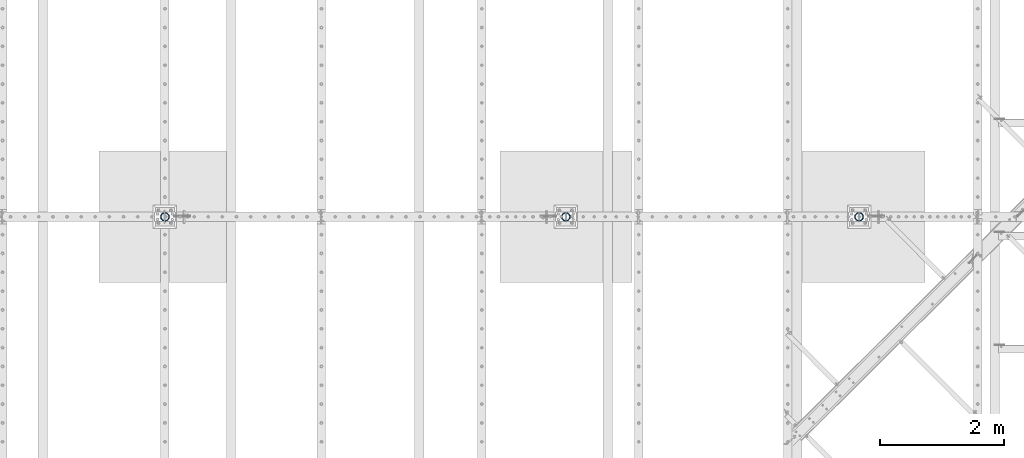
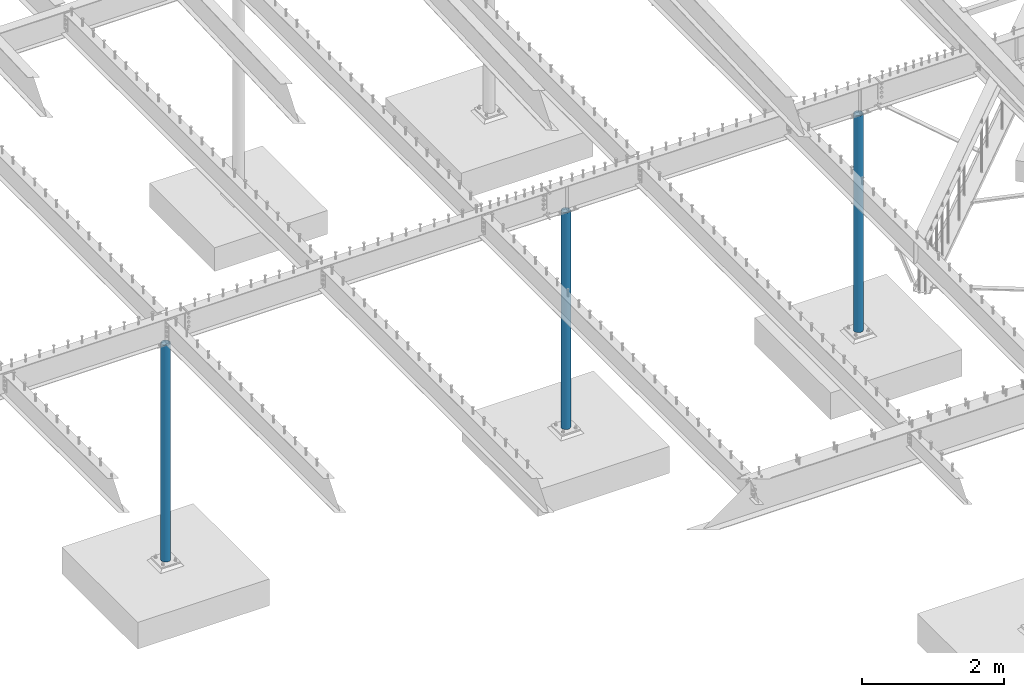
# One storey, part 123 of 975: 3 columns.
"""IFC2X3 building model written with IfcOpenShell, lengths in millimetres."""

from ifc_helpers import new_model, si_unit, frame, origin_with_axes, place, context, subcontext, project, spatial, faceted_brep, material, type_object, element, save


model = new_model("IFC2X3")

# Units and contexts
model_context = context("Model", 3, precision=1e-05, world=origin_with_axes())
body_context = subcontext(model_context, "Body", "Model", "MODEL_VIEW")
ifc_project = project(units=[si_unit("LENGTHUNIT", "METRE", prefix="MILLI"), si_unit("AREAUNIT", "SQUARE_METRE"), si_unit("VOLUMEUNIT", "CUBIC_METRE"), si_unit("MASSUNIT", "GRAM", prefix="KILO"), si_unit("TIMEUNIT", "SECOND"), si_unit("PLANEANGLEUNIT", "RADIAN"), si_unit("SOLIDANGLEUNIT", "STERADIAN"), si_unit("THERMODYNAMICTEMPERATUREUNIT", "DEGREE_CELSIUS"), si_unit("LUMINOUSINTENSITYUNIT", "LUMEN")], contexts=[model_context])

# Site, building, storey
site_placement = place(None, origin_with_axes())
site = spatial("IfcSite", under=ifc_project, at=site_placement, CompositionType="ELEMENT")
building_placement = place(site_placement, origin_with_axes())
building = spatial("IfcBuilding", under=site, at=building_placement, Name="Undefined", CompositionType="ELEMENT")
storey_placement = place(building_placement, origin_with_axes())
storey = spatial("IfcBuildingStorey", under=building, at=storey_placement, Name="Undefined", CompositionType="ELEMENT", Elevation=0.0)

# Columns
ifc_material = material(Name="STEEL/A53")
column_type = type_object("IfcColumnType", Name="PIPE5XS", PredefinedType="NOTDEFINED")
column_1_placement = place(storey_placement, frame((24725.3125, 13392.15, -266.7), z_axis=(0.0, 1.0, 0.0), x_axis=(0.0, 0.0, 1.0)))
element("IfcColumn", 1, at=column_1_placement, inside=storey, type_object=column_type, material=ifc_material, Name="COLUMN", ObjectType="PIPE5XS", context=body_context, shape_type="Brep", body=[
    faceted_brep([(25.3999999999999, -61.0869999999995, 0.0), (25.3999999999999, -58.0971894109207, 18.8769211353829), (3740.15, -58.0971894109207, 18.8769211353829), (3740.15, -61.0869999999995, 0.0), (25.3999999999999, -49.4204211353826, 35.9060377067908), (3740.15, -49.4204211353826, 35.9060377067908), (25.3999999999999, -35.9060377067908, 49.4204211353826), (3740.15, -35.9060377067908, 49.4204211353826), (25.3999999999999, -18.8769211353829, 58.0971894109225), (3740.15, -18.8769211353829, 58.0971894109225), (25.3999999999999, 0.0, 61.0869999999995), (3740.15, 0.0, 61.0869999999995), (25.3999999999999, 18.8769211353829, 58.0971894109225), (3740.15, 18.8769211353829, 58.0971894109225), (25.3999999999999, 35.9060377067908, 49.4204211353826), (3740.15, 35.9060377067908, 49.4204211353826), (25.3999999999999, 49.4204211353826, 35.9060377067908), (3740.15, 49.4204211353826, 35.9060377067908), (25.3999999999999, 58.0971894109207, 18.8769211353829), (3740.15, 58.0971894109207, 18.8769211353829), (25.3999999999999, 61.0869999999995, 0.0), (3740.15, 61.0869999999995, 0.0), (25.3999999999999, 58.0971894109207, -18.8769211353829), (3740.15, 58.0971894109207, -18.8769211353829), (25.3999999999999, 49.4204211353826, -35.9060377067908), (3740.15, 49.4204211353826, -35.9060377067908), (25.3999999999999, 35.9060377067908, -49.4204211353826), (3740.15, 35.9060377067908, -49.4204211353826), (25.3999999999999, 18.8769211353829, -58.0971894109225), (3740.15, 18.8769211353829, -58.0971894109225), (25.3999999999999, 0.0, -61.0869999999995), (3740.15, 0.0, -61.0869999999995), (25.3999999999999, -18.8769211353829, -58.0971894109225), (3740.15, -18.8769211353829, -58.0971894109225), (25.3999999999999, -35.9060377067908, -49.4204211353826), (3740.15, -35.9060377067908, -49.4204211353826), (25.3999999999999, -49.4204211353826, -35.9060377067908), (3740.15, -49.4204211353826, -35.9060377067908), (25.3999999999999, -58.0971894109207, -18.8769211353829), (3740.15, -58.0971894109207, -18.8769211353829), (25.3999999999999, -70.612000000001, 0.0), (25.3999999999999, -67.1560027286323, -21.8203080068042), (3740.15, -67.1560027286323, -21.8203080068042), (3740.15, -70.612000000001, 0.0), (25.3999999999999, -57.126308006802, -41.5046922348765), (3740.15, -57.126308006802, -41.5046922348765), (25.3999999999999, -41.5046922348774, -57.1263080068038), (3740.15, -41.5046922348774, -57.1263080068038), (25.3999999999999, -21.8203080068051, -67.1560027286332), (3740.15, -21.8203080068051, -67.1560027286332), (25.3999999999999, 0.0, -70.6120000000001), (3740.15, 0.0, -70.6120000000001), (25.3999999999999, 21.8203080068051, -67.1560027286332), (3740.15, 21.8203080068051, -67.1560027286332), (25.3999999999999, 41.5046922348774, -57.1263080068038), (3740.15, 41.5046922348774, -57.1263080068038), (25.3999999999999, 57.126308006802, -41.5046922348765), (3740.15, 57.126308006802, -41.5046922348765), (25.3999999999999, 67.1560027286323, -21.8203080068042), (3740.15, 67.1560027286323, -21.8203080068042), (25.3999999999999, 70.612000000001, 0.0), (3740.15, 70.612000000001, 0.0), (25.3999999999999, 67.1560027286323, 21.8203080068042), (3740.15, 67.1560027286323, 21.8203080068042), (25.3999999999999, 57.126308006802, 41.5046922348765), (3740.15, 57.126308006802, 41.5046922348765), (25.3999999999999, 41.5046922348774, 57.1263080068038), (3740.15, 41.5046922348774, 57.1263080068038), (25.3999999999999, 21.8203080068051, 67.1560027286332), (3740.15, 21.8203080068051, 67.1560027286332), (25.3999999999999, 0.0, 70.6120000000001), (3740.15, 0.0, 70.6120000000001), (25.3999999999999, -21.8203080068051, 67.1560027286332), (3740.15, -21.8203080068051, 67.1560027286332), (25.3999999999999, -41.5046922348774, 57.1263080068038), (3740.15, -41.5046922348774, 57.1263080068038), (25.3999999999999, -57.126308006802, 41.5046922348765), (3740.15, -57.126308006802, 41.5046922348765), (25.3999999999999, -67.1560027286323, 21.8203080068042), (3740.15, -67.1560027286323, 21.8203080068042)], [[[0, 1, 2, 3]], [[1, 4, 5, 2]], [[4, 6, 7, 5]], [[6, 8, 9, 7]], [[8, 10, 11, 9]], [[10, 12, 13, 11]], [[12, 14, 15, 13]], [[14, 16, 17, 15]], [[16, 18, 19, 17]], [[18, 20, 21, 19]], [[20, 22, 23, 21]], [[22, 24, 25, 23]], [[24, 26, 27, 25]], [[26, 28, 29, 27]], [[28, 30, 31, 29]], [[30, 32, 33, 31]], [[32, 34, 35, 33]], [[34, 36, 37, 35]], [[36, 38, 39, 37]], [[38, 0, 3, 39]], [[40, 41, 42, 43]], [[41, 44, 45, 42]], [[44, 46, 47, 45]], [[46, 48, 49, 47]], [[48, 50, 51, 49]], [[50, 52, 53, 51]], [[52, 54, 55, 53]], [[54, 56, 57, 55]], [[56, 58, 59, 57]], [[58, 60, 61, 59]], [[60, 62, 63, 61]], [[62, 64, 65, 63]], [[64, 66, 67, 65]], [[66, 68, 69, 67]], [[68, 70, 71, 69]], [[70, 72, 73, 71]], [[72, 74, 75, 73]], [[74, 76, 77, 75]], [[76, 78, 79, 77]], [[78, 40, 43, 79]], [[45, 47, 49, 51, 53, 55, 57, 59, 61, 63, 65, 67, 69, 71, 73, 75, 77, 79, 43, 42], [5, 7, 9, 11, 13, 15, 17, 19, 21, 23, 25, 27, 29, 31, 33, 35, 37, 39, 3, 2]], [[78, 76, 74, 72, 70, 68, 66, 64, 62, 60, 58, 56, 54, 52, 50, 48, 46, 44, 41, 40], [38, 36, 34, 32, 30, 28, 26, 24, 22, 20, 18, 16, 14, 12, 10, 8, 6, 4, 1, 0]]]),
])
column_2_placement = place(storey_placement, frame((19978.6875, 13392.15, -266.7), z_axis=(0.0, 1.0, 0.0), x_axis=(0.0, 0.0, 1.0)))
element("IfcColumn", 2, at=column_2_placement, inside=storey, type_object=column_type, material=ifc_material, Name="COLUMN", ObjectType="PIPE5XS", context=body_context, shape_type="Brep", body=[
    faceted_brep([(25.3999999999999, -61.0869999999995, 0.0), (25.3999999999999, -58.0971894109207, 18.8769211353829), (3740.15, -58.0971894109207, 18.8769211353829), (3740.15, -61.0869999999995, 0.0), (25.3999999999999, -49.4204211353826, 35.9060377067908), (3740.15, -49.4204211353826, 35.9060377067908), (25.3999999999999, -35.9060377067908, 49.4204211353826), (3740.15, -35.9060377067908, 49.4204211353826), (25.3999999999999, -18.8769211353829, 58.0971894109225), (3740.15, -18.8769211353829, 58.0971894109225), (25.3999999999999, 0.0, 61.0869999999995), (3740.15, 0.0, 61.0869999999995), (25.3999999999999, 18.8769211353829, 58.0971894109225), (3740.15, 18.8769211353829, 58.0971894109225), (25.3999999999999, 35.9060377067908, 49.4204211353826), (3740.15, 35.9060377067908, 49.4204211353826), (25.3999999999999, 49.4204211353826, 35.9060377067908), (3740.15, 49.4204211353826, 35.9060377067908), (25.3999999999999, 58.0971894109207, 18.8769211353829), (3740.15, 58.0971894109207, 18.8769211353829), (25.3999999999999, 61.0869999999995, 0.0), (3740.15, 61.0869999999995, 0.0), (25.3999999999999, 58.0971894109207, -18.8769211353829), (3740.15, 58.0971894109207, -18.8769211353829), (25.3999999999999, 49.4204211353826, -35.9060377067908), (3740.15, 49.4204211353826, -35.9060377067908), (25.3999999999999, 35.9060377067908, -49.4204211353826), (3740.15, 35.9060377067908, -49.4204211353826), (25.3999999999999, 18.8769211353829, -58.0971894109225), (3740.15, 18.8769211353829, -58.0971894109225), (25.3999999999999, 0.0, -61.0869999999995), (3740.15, 0.0, -61.0869999999995), (25.3999999999999, -18.8769211353829, -58.0971894109225), (3740.15, -18.8769211353829, -58.0971894109225), (25.3999999999999, -35.9060377067908, -49.4204211353826), (3740.15, -35.9060377067908, -49.4204211353826), (25.3999999999999, -49.4204211353826, -35.9060377067908), (3740.15, -49.4204211353826, -35.9060377067908), (25.3999999999999, -58.0971894109207, -18.8769211353829), (3740.15, -58.0971894109207, -18.8769211353829), (25.3999999999999, -70.612000000001, 0.0), (25.3999999999999, -67.1560027286323, -21.8203080068042), (3740.15, -67.1560027286323, -21.8203080068042), (3740.15, -70.612000000001, 0.0), (25.3999999999999, -57.126308006802, -41.5046922348765), (3740.15, -57.126308006802, -41.5046922348765), (25.3999999999999, -41.5046922348774, -57.1263080068038), (3740.15, -41.5046922348774, -57.1263080068038), (25.3999999999999, -21.8203080068051, -67.1560027286332), (3740.15, -21.8203080068051, -67.1560027286332), (25.3999999999999, 0.0, -70.6120000000001), (3740.15, 0.0, -70.6120000000001), (25.3999999999999, 21.8203080068051, -67.1560027286332), (3740.15, 21.8203080068051, -67.1560027286332), (25.3999999999999, 41.5046922348774, -57.1263080068038), (3740.15, 41.5046922348774, -57.1263080068038), (25.3999999999999, 57.126308006802, -41.5046922348765), (3740.15, 57.126308006802, -41.5046922348765), (25.3999999999999, 67.1560027286323, -21.8203080068042), (3740.15, 67.1560027286323, -21.8203080068042), (25.3999999999999, 70.612000000001, 0.0), (3740.15, 70.612000000001, 0.0), (25.3999999999999, 67.1560027286323, 21.8203080068042), (3740.15, 67.1560027286323, 21.8203080068042), (25.3999999999999, 57.126308006802, 41.5046922348765), (3740.15, 57.126308006802, 41.5046922348765), (25.3999999999999, 41.5046922348774, 57.1263080068038), (3740.15, 41.5046922348774, 57.1263080068038), (25.3999999999999, 21.8203080068051, 67.1560027286332), (3740.15, 21.8203080068051, 67.1560027286332), (25.3999999999999, 0.0, 70.6120000000001), (3740.15, 0.0, 70.6120000000001), (25.3999999999999, -21.8203080068051, 67.1560027286332), (3740.15, -21.8203080068051, 67.1560027286332), (25.3999999999999, -41.5046922348774, 57.1263080068038), (3740.15, -41.5046922348774, 57.1263080068038), (25.3999999999999, -57.126308006802, 41.5046922348765), (3740.15, -57.126308006802, 41.5046922348765), (25.3999999999999, -67.1560027286323, 21.8203080068042), (3740.15, -67.1560027286323, 21.8203080068042)], [[[0, 1, 2, 3]], [[1, 4, 5, 2]], [[4, 6, 7, 5]], [[6, 8, 9, 7]], [[8, 10, 11, 9]], [[10, 12, 13, 11]], [[12, 14, 15, 13]], [[14, 16, 17, 15]], [[16, 18, 19, 17]], [[18, 20, 21, 19]], [[20, 22, 23, 21]], [[22, 24, 25, 23]], [[24, 26, 27, 25]], [[26, 28, 29, 27]], [[28, 30, 31, 29]], [[30, 32, 33, 31]], [[32, 34, 35, 33]], [[34, 36, 37, 35]], [[36, 38, 39, 37]], [[38, 0, 3, 39]], [[40, 41, 42, 43]], [[41, 44, 45, 42]], [[44, 46, 47, 45]], [[46, 48, 49, 47]], [[48, 50, 51, 49]], [[50, 52, 53, 51]], [[52, 54, 55, 53]], [[54, 56, 57, 55]], [[56, 58, 59, 57]], [[58, 60, 61, 59]], [[60, 62, 63, 61]], [[62, 64, 65, 63]], [[64, 66, 67, 65]], [[66, 68, 69, 67]], [[68, 70, 71, 69]], [[70, 72, 73, 71]], [[72, 74, 75, 73]], [[74, 76, 77, 75]], [[76, 78, 79, 77]], [[78, 40, 43, 79]], [[45, 47, 49, 51, 53, 55, 57, 59, 61, 63, 65, 67, 69, 71, 73, 75, 77, 79, 43, 42], [5, 7, 9, 11, 13, 15, 17, 19, 21, 23, 25, 27, 29, 31, 33, 35, 37, 39, 3, 2]], [[78, 76, 74, 72, 70, 68, 66, 64, 62, 60, 58, 56, 54, 52, 50, 48, 46, 44, 41, 40], [38, 36, 34, 32, 30, 28, 26, 24, 22, 20, 18, 16, 14, 12, 10, 8, 6, 4, 1, 0]]]),
])
column_3_placement = place(storey_placement, frame((13487.4, 13392.15, -266.7), z_axis=(0.0, 1.0, 0.0), x_axis=(0.0, 0.0, 1.0)))
element("IfcColumn", 3, at=column_3_placement, inside=storey, type_object=column_type, material=ifc_material, Name="COLUMN", ObjectType="PIPE5XS", context=body_context, shape_type="Brep", body=[
    faceted_brep([(25.3999999999999, -61.0869999999995, 0.0), (25.3999999999999, -58.0971894109207, 18.8769211353829), (3740.15, -58.0971894109207, 18.8769211353829), (3740.15, -61.0869999999995, 0.0), (25.3999999999999, -49.4204211353826, 35.9060377067908), (3740.15, -49.4204211353826, 35.9060377067908), (25.3999999999999, -35.9060377067908, 49.4204211353826), (3740.15, -35.9060377067908, 49.4204211353826), (25.3999999999999, -18.8769211353829, 58.0971894109225), (3740.15, -18.8769211353829, 58.0971894109225), (25.3999999999999, 0.0, 61.0869999999995), (3740.15, 0.0, 61.0869999999995), (25.3999999999999, 18.8769211353829, 58.0971894109225), (3740.15, 18.8769211353829, 58.0971894109225), (25.3999999999999, 35.9060377067908, 49.4204211353826), (3740.15, 35.9060377067908, 49.4204211353826), (25.3999999999999, 49.4204211353826, 35.9060377067908), (3740.15, 49.4204211353826, 35.9060377067908), (25.3999999999999, 58.0971894109207, 18.8769211353829), (3740.15, 58.0971894109207, 18.8769211353829), (25.3999999999999, 61.0869999999995, 0.0), (3740.15, 61.0869999999995, 0.0), (25.3999999999999, 58.0971894109207, -18.8769211353829), (3740.15, 58.0971894109207, -18.8769211353829), (25.3999999999999, 49.4204211353826, -35.9060377067908), (3740.15, 49.4204211353826, -35.9060377067908), (25.3999999999999, 35.9060377067908, -49.4204211353826), (3740.15, 35.9060377067908, -49.4204211353826), (25.3999999999999, 18.8769211353829, -58.0971894109225), (3740.15, 18.8769211353829, -58.0971894109225), (25.3999999999999, 0.0, -61.0869999999995), (3740.15, 0.0, -61.0869999999995), (25.3999999999999, -18.8769211353829, -58.0971894109225), (3740.15, -18.8769211353829, -58.0971894109225), (25.3999999999999, -35.9060377067908, -49.4204211353826), (3740.15, -35.9060377067908, -49.4204211353826), (25.3999999999999, -49.4204211353826, -35.9060377067908), (3740.15, -49.4204211353826, -35.9060377067908), (25.3999999999999, -58.0971894109207, -18.8769211353829), (3740.15, -58.0971894109207, -18.8769211353829), (25.3999999999999, -70.612000000001, 0.0), (25.3999999999999, -67.1560027286323, -21.8203080068042), (3740.15, -67.1560027286323, -21.8203080068042), (3740.15, -70.612000000001, 0.0), (25.3999999999999, -57.126308006802, -41.5046922348765), (3740.15, -57.126308006802, -41.5046922348765), (25.3999999999999, -41.5046922348774, -57.1263080068038), (3740.15, -41.5046922348774, -57.1263080068038), (25.3999999999999, -21.8203080068051, -67.1560027286332), (3740.15, -21.8203080068051, -67.1560027286332), (25.3999999999999, 0.0, -70.6120000000001), (3740.15, 0.0, -70.6120000000001), (25.3999999999999, 21.8203080068051, -67.1560027286332), (3740.15, 21.8203080068051, -67.1560027286332), (25.3999999999999, 41.5046922348774, -57.1263080068038), (3740.15, 41.5046922348774, -57.1263080068038), (25.3999999999999, 57.126308006802, -41.5046922348765), (3740.15, 57.126308006802, -41.5046922348765), (25.3999999999999, 67.1560027286323, -21.8203080068042), (3740.15, 67.1560027286323, -21.8203080068042), (25.3999999999999, 70.612000000001, 0.0), (3740.15, 70.612000000001, 0.0), (25.3999999999999, 67.1560027286323, 21.8203080068042), (3740.15, 67.1560027286323, 21.8203080068042), (25.3999999999999, 57.126308006802, 41.5046922348765), (3740.15, 57.126308006802, 41.5046922348765), (25.3999999999999, 41.5046922348774, 57.1263080068038), (3740.15, 41.5046922348774, 57.1263080068038), (25.3999999999999, 21.8203080068051, 67.1560027286332), (3740.15, 21.8203080068051, 67.1560027286332), (25.3999999999999, 0.0, 70.6120000000001), (3740.15, 0.0, 70.6120000000001), (25.3999999999999, -21.8203080068051, 67.1560027286332), (3740.15, -21.8203080068051, 67.1560027286332), (25.3999999999999, -41.5046922348774, 57.1263080068038), (3740.15, -41.5046922348774, 57.1263080068038), (25.3999999999999, -57.126308006802, 41.5046922348765), (3740.15, -57.126308006802, 41.5046922348765), (25.3999999999999, -67.1560027286323, 21.8203080068042), (3740.15, -67.1560027286323, 21.8203080068042)], [[[0, 1, 2, 3]], [[1, 4, 5, 2]], [[4, 6, 7, 5]], [[6, 8, 9, 7]], [[8, 10, 11, 9]], [[10, 12, 13, 11]], [[12, 14, 15, 13]], [[14, 16, 17, 15]], [[16, 18, 19, 17]], [[18, 20, 21, 19]], [[20, 22, 23, 21]], [[22, 24, 25, 23]], [[24, 26, 27, 25]], [[26, 28, 29, 27]], [[28, 30, 31, 29]], [[30, 32, 33, 31]], [[32, 34, 35, 33]], [[34, 36, 37, 35]], [[36, 38, 39, 37]], [[38, 0, 3, 39]], [[40, 41, 42, 43]], [[41, 44, 45, 42]], [[44, 46, 47, 45]], [[46, 48, 49, 47]], [[48, 50, 51, 49]], [[50, 52, 53, 51]], [[52, 54, 55, 53]], [[54, 56, 57, 55]], [[56, 58, 59, 57]], [[58, 60, 61, 59]], [[60, 62, 63, 61]], [[62, 64, 65, 63]], [[64, 66, 67, 65]], [[66, 68, 69, 67]], [[68, 70, 71, 69]], [[70, 72, 73, 71]], [[72, 74, 75, 73]], [[74, 76, 77, 75]], [[76, 78, 79, 77]], [[78, 40, 43, 79]], [[45, 47, 49, 51, 53, 55, 57, 59, 61, 63, 65, 67, 69, 71, 73, 75, 77, 79, 43, 42], [5, 7, 9, 11, 13, 15, 17, 19, 21, 23, 25, 27, 29, 31, 33, 35, 37, 39, 3, 2]], [[78, 76, 74, 72, 70, 68, 66, 64, 62, 60, 58, 56, 54, 52, 50, 48, 46, 44, 41, 40], [38, 36, 34, 32, 30, 28, 26, 24, 22, 20, 18, 16, 14, 12, 10, 8, 6, 4, 1, 0]]]),
])

save(model, "model.ifc")
